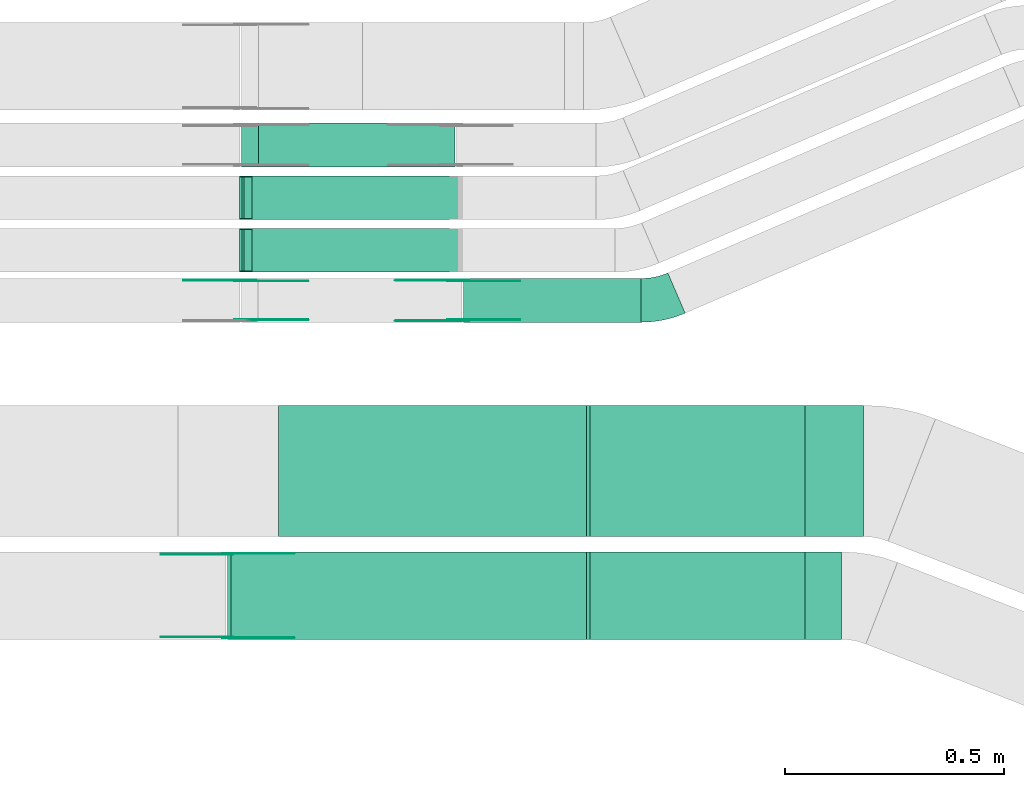
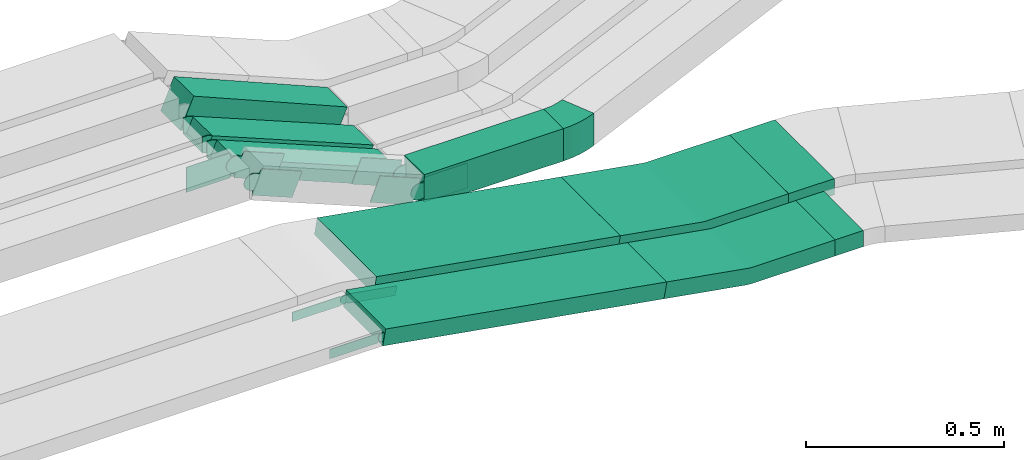
# One storey, part 16 of 31: 16 flow fittings, 8 flow segments.
"""IFC2X3 building model written with IfcOpenShell, lengths in millimetres."""

from ifc_helpers import new_model, entity, si_unit, converted_unit, derived_unit, direction, frame, frame_2d, origin, origin_2d_with_axis, place, context, subcontext, project, spatial, polyline, circle_curve, parameter, trimmed, segment, composite_curve, rectangle, outline, extrude, faceted_brep, source, transform, mapped, material, type_object, type_shapes, element, save


model = new_model("IFC2X3")

# Units and contexts
model_context = context("Model", 3, precision=0.01, world=origin(), true_north=direction((6.12303176911189e-17, 1.0)))
body_context = subcontext(model_context, "Body", "Model", "MODEL_VIEW")
ifc_project = project(units=[si_unit("LENGTHUNIT", "METRE", prefix="MILLI"), si_unit("AREAUNIT", "SQUARE_METRE"), si_unit("VOLUMEUNIT", "CUBIC_METRE"), converted_unit("PLANEANGLEUNIT", "DEGREE", entity("IfcRatioMeasure", 0.0174532925199433), si_unit("PLANEANGLEUNIT", "RADIAN"), dimensions=[0, 0, 0, 0, 0, 0, 0]), si_unit("MASSUNIT", "GRAM", prefix="KILO"), derived_unit("MASSDENSITYUNIT", [(si_unit("MASSUNIT", "GRAM", prefix="KILO"), 1), (si_unit("LENGTHUNIT", "METRE"), -3)]), derived_unit("MOMENTOFINERTIAUNIT", [(si_unit("LENGTHUNIT", "METRE"), 4)]), si_unit("TIMEUNIT", "SECOND"), si_unit("FREQUENCYUNIT", "HERTZ"), si_unit("THERMODYNAMICTEMPERATUREUNIT", "DEGREE_CELSIUS"), derived_unit("THERMALTRANSMITTANCEUNIT", [(si_unit("MASSUNIT", "GRAM", prefix="KILO"), 1), (si_unit("THERMODYNAMICTEMPERATUREUNIT", "KELVIN"), -1), (si_unit("TIMEUNIT", "SECOND"), -3)]), derived_unit("VOLUMETRICFLOWRATEUNIT", [(si_unit("LENGTHUNIT", "METRE"), 3), (si_unit("TIMEUNIT", "SECOND"), -1)]), derived_unit("MASSFLOWRATEUNIT", [(si_unit("MASSUNIT", "GRAM", prefix="KILO"), 1), (si_unit("TIMEUNIT", "SECOND"), -1)]), derived_unit("ROTATIONALFREQUENCYUNIT", [(si_unit("TIMEUNIT", "SECOND"), -1)]), si_unit("ELECTRICCURRENTUNIT", "AMPERE"), si_unit("ELECTRICVOLTAGEUNIT", "VOLT"), si_unit("POWERUNIT", "WATT"), si_unit("FORCEUNIT", "NEWTON", prefix="KILO"), si_unit("ILLUMINANCEUNIT", "LUX"), si_unit("LUMINOUSFLUXUNIT", "LUMEN"), si_unit("LUMINOUSINTENSITYUNIT", "CANDELA"), derived_unit("USERDEFINED", [(si_unit("MASSUNIT", "GRAM", prefix="KILO"), -1), (si_unit("LENGTHUNIT", "METRE"), -2), (si_unit("TIMEUNIT", "SECOND"), 3), (si_unit("LUMINOUSFLUXUNIT", "LUMEN"), 1)]), derived_unit("LINEARVELOCITYUNIT", [(si_unit("LENGTHUNIT", "METRE"), 1), (si_unit("TIMEUNIT", "SECOND"), -1)]), si_unit("PRESSUREUNIT", "PASCAL"), derived_unit("USERDEFINED", [(si_unit("LENGTHUNIT", "METRE"), -2), (si_unit("MASSUNIT", "GRAM", prefix="KILO"), 1), (si_unit("TIMEUNIT", "SECOND"), -2)]), derived_unit("LINEARFORCEUNIT", [(si_unit("MASSUNIT", "GRAM", prefix="KILO"), 1), (si_unit("LENGTHUNIT", "METRE"), 1), (si_unit("TIMEUNIT", "SECOND"), -2), (si_unit("LENGTHUNIT", "METRE"), -1)]), derived_unit("PLANARFORCEUNIT", [(si_unit("MASSUNIT", "GRAM", prefix="KILO"), 1), (si_unit("LENGTHUNIT", "METRE"), 1), (si_unit("TIMEUNIT", "SECOND"), -2), (si_unit("LENGTHUNIT", "METRE"), -2)])], contexts=[model_context])

# Site, building, storey
site_placement = place(None, frame((0.0, -0.00077364408347762, 0.0)))
site = spatial("IfcSite", under=ifc_project, at=site_placement, CompositionType="ELEMENT")
building_placement = place(site_placement, origin())
building = spatial("IfcBuilding", under=site, at=building_placement, CompositionType="ELEMENT")
storey_placement = place(building_placement, frame((0.0, 0.0, 15900.0)))
storey = spatial("IfcBuildingStorey", under=building, at=storey_placement, CompositionType="ELEMENT", Elevation=15900.0)

# Flow segments
cable_carrier_segment_type = type_object("IfcCableCarrierSegmentType", PredefinedType="CABLETRAYSEGMENT")
flow_segment_1_placement = place(storey_placement, frame((45693.9474929128, 15124.9939089947, 2634.94956318969)))
element("IfcFlowSegment", 1, at=flow_segment_1_placement, inside=storey, type_object=cable_carrier_segment_type, context=body_context, shape_type="SweptSolid", body=[
    extrude(rectangle(XDim=406.031422459047, YDim=99.9999999999989, at=frame_2d((0.0, -1.08357767203415e-12), x_axis=(1.0, 0.0))), frame((203.015711229523, 50.0, 0.0)), (0.0, 0.0, 1.0), 99.9999999999989),
])
flow_segment_2_placement = place(storey_placement, frame((45191.3085759631, 15239.4580000517, 2642.86123897901)))
element("IfcFlowSegment", 2, at=flow_segment_2_placement, inside=storey, type_object=cable_carrier_segment_type, context=body_context, shape_type="SweptSolid", body=[
    extrude(rectangle(XDim=50.0000000000019, YDim=99.9999999999989, at=frame_2d((-1.00186525742174e-12, 2.16715534406831e-12), x_axis=(1.0, 0.0))), frame((9.49229224874441, 50.0, 216.395545412713), z_axis=(0.925113085294563, 0.0, -0.379691689949589), x_axis=(0.379691689949589, 0.0, 0.925113085294563)), (0.0, 0.0, 1.0), 509.012241763836),
])
flow_segment_3_placement = place(storey_placement, frame((45191.308575963, 15359.4580000518, 2642.86123897902)))
element("IfcFlowSegment", 3, at=flow_segment_3_placement, inside=storey, type_object=cable_carrier_segment_type, context=body_context, shape_type="SweptSolid", body=[
    extrude(rectangle(XDim=50.0000000000092, YDim=99.9999999999989, at=origin_2d_with_axis()), frame((9.49229224874441, 50.0, 216.395545412369), z_axis=(0.925113085294515, 0.0, -0.379691689949707), x_axis=(0.379691689949707, 0.0, 0.925113085294515)), (0.0, 0.0, 1.0), 509.012241762945),
])
flow_segment_4_placement = place(storey_placement, frame((45186.4911009639, 15479.9939089947, 2643.66817627978)))
element("IfcFlowSegment", 4, at=flow_segment_4_placement, inside=storey, type_object=cable_carrier_segment_type, context=body_context, shape_type="SweptSolid", body=[
    extrude(rectangle(XDim=99.9999999999968, YDim=99.9999999999989, at=frame_2d((0.0, -2.16715534406831e-12), x_axis=(1.0, 0.0))), frame((19.5475726940318, 50.0, 236.643082452827), z_axis=(0.92041129975061, 0.0, -0.390951453880648), x_axis=(0.390951453880648, 0.0, 0.92041129975061)), (0.0, 0.0, 1.0), 487.586158263763),
])
flow_segment_5_placement = place(storey_placement, frame((46475.2400350506, 14635.0255085139, 2650.0)))
element("IfcFlowSegment", 5, at=flow_segment_5_placement, inside=storey, type_object=cable_carrier_segment_type, context=body_context, shape_type="SweptSolid", body=[
    extrude(rectangle(XDim=133.135877151261, YDim=300.000000000001, at=origin_2d_with_axis()), frame((66.5679385756305, 150.0, 0.0), z_axis=(0.0, 0.0, 1.0), x_axis=(-1.0, 0.0, 0.0)), (0.0, 0.0, 1.0), 50.0000000000016),
])
flow_segment_6_placement = place(storey_placement, frame((46475.2400350506, 14400.0255085139, 2650.0)))
element("IfcFlowSegment", 6, at=flow_segment_6_placement, inside=storey, type_object=cable_carrier_segment_type, context=body_context, shape_type="SweptSolid", body=[
    extrude(rectangle(XDim=82.4973887325516, YDim=200.000000000002, at=frame_2d((-4.33075797445781e-12, 0.0), x_axis=(1.0, 0.0))), frame((41.2486943662715, 100.0, 0.0), z_axis=(0.0, 0.0, 1.0), x_axis=(-1.0, 0.0, 0.0)), (0.0, 0.0, 1.0), 50.0000000000038),
])
flow_segment_7_placement = place(storey_placement, frame((45154.3195818992, 14400.0255085139, 2692.89003524465)))
element("IfcFlowSegment", 7, at=flow_segment_7_placement, inside=storey, type_object=cable_carrier_segment_type, context=body_context, shape_type="SweptSolid", body=[
    extrude(rectangle(XDim=49.9999999999991, YDim=199.999999999998, at=origin_2d_with_axis()), frame((4.25767461585183, 100.0, 166.51599836149), z_axis=(0.985391054853274, 0.0, -0.170306984634076), x_axis=(0.170306984634076, 0.0, 0.985391054853274)), (0.0, 0.0, 1.0), 833.091034374861),
])
flow_segment_8_placement = place(storey_placement, frame((45262.9235421238, 14635.0255085139, 2692.89003524465)))
element("IfcFlowSegment", 8, at=flow_segment_8_placement, inside=storey, type_object=cable_carrier_segment_type, context=body_context, shape_type="SweptSolid", body=[
    extrude(rectangle(XDim=49.9999999999991, YDim=300.000000000001, at=origin_2d_with_axis()), frame((4.25767461585183, 150.0, 147.745772171508), z_axis=(0.985391054853274, 0.0, -0.170306984634076), x_axis=(0.170306984634076, 0.0, 0.985391054853274)), (0.0, 0.0, 1.0), 722.876962824568),
])

# Flow fittings
ifc_material_1 = material(Name="G")
cable_carrier_fitting_type_1 = type_object("IfcCableCarrierFittingType", PredefinedType="NOTDEFINED", material=ifc_material_1)
shared_shape_1 = source(origin(), body_context, "Body", "SweptSolid", [
    extrude(outline(composite_curve([segment(trimmed(circle_curve(frame_2d((-44.5901162790698, 0.0), x_axis=(1.0, 0.0)), 12.5), [parameter(90.0000000000007)], [parameter(270.0)], True, "PARAMETER"), True, "CONTINUOUS"), segment(polyline([(-44.5901162790697, -12.5), (-33.0901162790698, -12.5)]), True, "CONTINUOUS"), segment(polyline([(-33.0901162790698, -12.5), (-31.2296511627907, -14.5)]), True, "CONTINUOUS"), segment(polyline([(-31.2296511627907, -14.5), (108.90988372093, -14.5)]), True, "CONTINUOUS"), segment(polyline([(108.90988372093, -14.5), (108.90988372093, 14.5)]), True, "CONTINUOUS"), segment(polyline([(108.90988372093, 14.5), (-31.2296511627907, 14.5)]), True, "CONTINUOUS"), segment(polyline([(-31.2296511627907, 14.5), (-33.0901162790698, 12.5)]), True, "CONTINUOUS"), segment(polyline([(-33.0901162790698, 12.5), (-44.5901162790699, 12.5)]), True, "CONTINUOUS")], self_intersect=False)), frame((44.5901162790698, 0.0, 0.0), z_axis=(0.0, 0.0, -1.0), x_axis=(1.0, 0.0, 0.0)), (0.0, 0.0, -1.0), 2.0),
])
type_shapes(cable_carrier_fitting_type_1, [shared_shape_1])
flow_fitting_1_placement = place(storey_placement, frame((45155.14058495, 14595.4855085241, 2860.0), z_axis=(0.0, 1.0, 0.0), x_axis=(0.985391054853256, 0.0, -0.170306984634182)))
element("IfcFlowFitting", 9, at=flow_fitting_1_placement, inside=storey, type_object=cable_carrier_fitting_type_1, material=ifc_material_1, context=body_context, shape_type="MappedRepresentation", body=[
    mapped(shared_shape_1, transform((0.0, 0.0, 0.0), scale=1.0)),
])
cable_carrier_fitting_type_2 = type_object("IfcCableCarrierFittingType", PredefinedType="NOTDEFINED", material=ifc_material_1)
shared_shape_2 = source(origin(), body_context, "Body", "SweptSolid", [
    extrude(outline(composite_curve([segment(trimmed(circle_curve(frame_2d((-44.5901162790697, 0.0), x_axis=(1.0, 0.0)), 12.5), [parameter(90.0000000000007)], [parameter(270.0)], True, "PARAMETER"), True, "CONTINUOUS"), segment(polyline([(-44.5901162790697, -12.5), (-33.0901162790697, -12.5)]), True, "CONTINUOUS"), segment(polyline([(-33.0901162790697, -12.5), (-31.2296511627907, -14.5)]), True, "CONTINUOUS"), segment(polyline([(-31.2296511627907, -14.5), (108.90988372093, -14.5)]), True, "CONTINUOUS"), segment(polyline([(108.90988372093, -14.5), (108.90988372093, 14.5)]), True, "CONTINUOUS"), segment(polyline([(108.90988372093, 14.5), (-31.2296511627907, 14.5)]), True, "CONTINUOUS"), segment(polyline([(-31.2296511627907, 14.5), (-33.0901162790698, 12.5)]), True, "CONTINUOUS"), segment(polyline([(-33.0901162790698, 12.5), (-44.5901162790699, 12.5)]), True, "CONTINUOUS")], self_intersect=False)), frame((44.5901162790697, 0.0, 0.0)), (0.0, 0.0, 1.0), 2.0),
])
type_shapes(cable_carrier_fitting_type_2, [shared_shape_2])
flow_fitting_2_placement = place(storey_placement, frame((45155.14058495, 14404.5655085037, 2860.0), z_axis=(0.0, -1.0, 0.0), x_axis=(0.985391054853256, 0.0, -0.170306984634182)))
element("IfcFlowFitting", 10, at=flow_fitting_2_placement, inside=storey, type_object=cable_carrier_fitting_type_2, material=ifc_material_1, context=body_context, shape_type="MappedRepresentation", body=[
    mapped(shared_shape_2, transform((0.0, 0.0, 0.0), scale=1.0)),
])
cable_carrier_fitting_type_3 = type_object("IfcCableCarrierFittingType", PredefinedType="NOTDEFINED", material=ifc_material_1)
shared_shape_3 = source(origin(), body_context, "Body", "SweptSolid", [
    extrude(outline(composite_curve([segment(trimmed(circle_curve(frame_2d((-44.5901162790698, 0.0), x_axis=(1.0, 0.0)), 12.5), [parameter(90.0000000000007)], [parameter(270.0)], True, "PARAMETER"), True, "CONTINUOUS"), segment(polyline([(-44.5901162790697, -12.5), (-33.0901162790698, -12.5)]), True, "CONTINUOUS"), segment(polyline([(-33.0901162790698, -12.5), (-31.2296511627907, -14.5)]), True, "CONTINUOUS"), segment(polyline([(-31.2296511627907, -14.5), (108.90988372093, -14.5)]), True, "CONTINUOUS"), segment(polyline([(108.90988372093, -14.5), (108.90988372093, 14.5)]), True, "CONTINUOUS"), segment(polyline([(108.90988372093, 14.5), (-31.2296511627907, 14.5)]), True, "CONTINUOUS"), segment(polyline([(-31.2296511627907, 14.5), (-33.0901162790698, 12.5)]), True, "CONTINUOUS"), segment(polyline([(-33.0901162790698, 12.5), (-44.5901162790699, 12.5)]), True, "CONTINUOUS")], self_intersect=False)), frame((44.5901162790698, 0.0, 0.0), z_axis=(0.0, 0.0, -1.0), x_axis=(1.0, 0.0, 0.0)), (0.0, 0.0, -1.0), 2.0),
])
type_shapes(cable_carrier_fitting_type_3, [shared_shape_3])
flow_fitting_3_placement = place(storey_placement, frame((45155.14058495, 14406.5655085037, 2860.0), z_axis=(0.0, -1.0, 0.0), x_axis=(-1.0, 0.0, 0.0)))
element("IfcFlowFitting", 11, at=flow_fitting_3_placement, inside=storey, type_object=cable_carrier_fitting_type_3, material=ifc_material_1, context=body_context, shape_type="MappedRepresentation", body=[
    mapped(shared_shape_3, transform((0.0, 0.0, 0.0), scale=1.0)),
])
cable_carrier_fitting_type_4 = type_object("IfcCableCarrierFittingType", PredefinedType="NOTDEFINED", material=ifc_material_1)
shared_shape_4 = source(origin(), body_context, "Body", "SweptSolid", [
    extrude(outline(composite_curve([segment(trimmed(circle_curve(frame_2d((-44.5901162790697, 0.0), x_axis=(1.0, 0.0)), 12.5), [parameter(90.0000000000007)], [parameter(270.0)], True, "PARAMETER"), True, "CONTINUOUS"), segment(polyline([(-44.5901162790697, -12.5), (-33.0901162790697, -12.5)]), True, "CONTINUOUS"), segment(polyline([(-33.0901162790697, -12.5), (-31.2296511627907, -14.5)]), True, "CONTINUOUS"), segment(polyline([(-31.2296511627907, -14.5), (108.90988372093, -14.5)]), True, "CONTINUOUS"), segment(polyline([(108.90988372093, -14.5), (108.90988372093, 14.5)]), True, "CONTINUOUS"), segment(polyline([(108.90988372093, 14.5), (-31.2296511627907, 14.5)]), True, "CONTINUOUS"), segment(polyline([(-31.2296511627907, 14.5), (-33.0901162790698, 12.5)]), True, "CONTINUOUS"), segment(polyline([(-33.0901162790698, 12.5), (-44.5901162790699, 12.5)]), True, "CONTINUOUS")], self_intersect=False)), frame((44.5901162790697, 0.0, 0.0)), (0.0, 0.0, 1.0), 2.0),
])
type_shapes(cable_carrier_fitting_type_4, [shared_shape_4])
flow_fitting_4_placement = place(storey_placement, frame((45155.14058495, 14593.485508524, 2860.0), z_axis=(0.0, 1.0, 0.0), x_axis=(-1.0, 0.0, 0.0)))
element("IfcFlowFitting", 12, at=flow_fitting_4_placement, inside=storey, type_object=cable_carrier_fitting_type_4, material=ifc_material_1, context=body_context, shape_type="MappedRepresentation", body=[
    mapped(shared_shape_4, transform((0.0, 0.0, 0.0), scale=1.0)),
])
cable_carrier_fitting_type_5 = type_object("IfcCableCarrierFittingType", PredefinedType="NOTDEFINED", material=ifc_material_1)
shared_shape_5 = source(origin(), body_context, "Body", "SweptSolid", [
    extrude(outline(composite_curve([segment(trimmed(circle_curve(frame_2d((-41.4651162790697, 0.0), x_axis=(1.0, 0.0)), 25.0), [parameter(90.0000000000007)], [parameter(270.0)], True, "PARAMETER"), True, "CONTINUOUS"), segment(polyline([(-41.4651162790697, -25.0), (-29.9651162790697, -25.0)]), True, "CONTINUOUS"), segment(polyline([(-29.9651162790697, -25.0), (-28.1046511627907, -38.5)]), True, "CONTINUOUS"), segment(polyline([(-28.1046511627907, -38.5), (99.5348837209303, -38.5)]), True, "CONTINUOUS"), segment(polyline([(99.5348837209303, -38.5), (99.5348837209303, 38.5)]), True, "CONTINUOUS"), segment(polyline([(99.5348837209303, 38.5), (-28.1046511627907, 38.5)]), True, "CONTINUOUS"), segment(polyline([(-28.1046511627907, 38.5), (-29.9651162790697, 25.0)]), True, "CONTINUOUS"), segment(polyline([(-29.9651162790697, 25.0), (-41.46511627907, 25.0)]), True, "CONTINUOUS")], self_intersect=False)), frame((41.4651162790697, 0.0, 0.0), z_axis=(0.0, 0.0, -1.0), x_axis=(1.0, 0.0, 0.0)), (0.0, 0.0, -1.0), 2.0),
])
type_shapes(cable_carrier_fitting_type_5, [shared_shape_5])
flow_fitting_5_placement = place(storey_placement, frame((45682.2970270189, 15220.4539090049, 2684.94956318967), z_axis=(0.0, 1.0, 0.0), x_axis=(-0.925113085296403, 0.0, 0.379691689945105)))
element("IfcFlowFitting", 13, at=flow_fitting_5_placement, inside=storey, type_object=cable_carrier_fitting_type_5, material=ifc_material_1, context=body_context, shape_type="MappedRepresentation", body=[
    mapped(shared_shape_5, transform((0.0, 0.0, 0.0), scale=1.0)),
])
cable_carrier_fitting_type_6 = type_object("IfcCableCarrierFittingType", PredefinedType="NOTDEFINED", material=ifc_material_1)
shared_shape_6 = source(origin(), body_context, "Body", "SweptSolid", [
    extrude(outline(composite_curve([segment(trimmed(circle_curve(frame_2d((-41.4651162790697, 0.0), x_axis=(1.0, 0.0)), 25.0), [parameter(90.0000000000007)], [parameter(270.0)], True, "PARAMETER"), True, "CONTINUOUS"), segment(polyline([(-41.4651162790697, -25.0), (-29.9651162790697, -25.0)]), True, "CONTINUOUS"), segment(polyline([(-29.9651162790697, -25.0), (-28.1046511627907, -38.5)]), True, "CONTINUOUS"), segment(polyline([(-28.1046511627907, -38.5), (99.5348837209303, -38.5)]), True, "CONTINUOUS"), segment(polyline([(99.5348837209303, -38.5), (99.5348837209303, 38.5)]), True, "CONTINUOUS"), segment(polyline([(99.5348837209303, 38.5), (-28.1046511627907, 38.5)]), True, "CONTINUOUS"), segment(polyline([(-28.1046511627907, 38.5), (-29.9651162790697, 25.0)]), True, "CONTINUOUS"), segment(polyline([(-29.9651162790697, 25.0), (-41.46511627907, 25.0)]), True, "CONTINUOUS")], self_intersect=False)), frame((41.4651162790697, 0.0, 0.0)), (0.0, 0.0, 1.0), 2.0),
])
type_shapes(cable_carrier_fitting_type_6, [shared_shape_6])
for number, where, z_axis, x_axis in (
    (14, (45194.98232223, 15220.4539090049, 2884.95683445177), (0.0, 1.0, 0.0), (-1.0, 0.0, 0.0)),
    (15, (45682.2970270189, 15129.5339089845, 2684.94956318967), (0.0, -1.0, 0.0), (-0.925113085296403, 0.0, 0.379691689945105)),
):
    element("IfcFlowFitting", number, at=place(storey_placement, frame(where, z_axis=z_axis, x_axis=x_axis)), inside=storey, type_object=cable_carrier_fitting_type_6, material=ifc_material_1, context=body_context, shape_type="MappedRepresentation", body=[
        mapped(shared_shape_6, transform((0.0, 0.0, 0.0), scale=1.0)),
    ])
cable_carrier_fitting_type_7 = type_object("IfcCableCarrierFittingType", PredefinedType="NOTDEFINED", material=ifc_material_1)
shared_shape_7 = source(origin(), body_context, "Body", "SweptSolid", [
    extrude(outline(composite_curve([segment(trimmed(circle_curve(frame_2d((-41.4651162790697, 0.0), x_axis=(1.0, 0.0)), 25.0), [parameter(90.0000000000007)], [parameter(270.0)], True, "PARAMETER"), True, "CONTINUOUS"), segment(polyline([(-41.4651162790697, -25.0), (-29.9651162790697, -25.0)]), True, "CONTINUOUS"), segment(polyline([(-29.9651162790697, -25.0), (-28.1046511627907, -38.5)]), True, "CONTINUOUS"), segment(polyline([(-28.1046511627907, -38.5), (99.5348837209303, -38.5)]), True, "CONTINUOUS"), segment(polyline([(99.5348837209303, -38.5), (99.5348837209303, 38.5)]), True, "CONTINUOUS"), segment(polyline([(99.5348837209303, 38.5), (-28.1046511627907, 38.5)]), True, "CONTINUOUS"), segment(polyline([(-28.1046511627907, 38.5), (-29.9651162790697, 25.0)]), True, "CONTINUOUS"), segment(polyline([(-29.9651162790697, 25.0), (-41.46511627907, 25.0)]), True, "CONTINUOUS")], self_intersect=False)), frame((41.4651162790697, 0.0, 0.0), z_axis=(0.0, 0.0, -1.0), x_axis=(1.0, 0.0, 0.0)), (0.0, 0.0, -1.0), 2.0),
])
type_shapes(cable_carrier_fitting_type_7, [shared_shape_7])
for number, where, z_axis, x_axis in (
    (16, (45194.98232223, 15218.4539090049, 2884.95683445177), (0.0, 1.0, 0.0), (0.925113085294536, 0.0, -0.379691689949654)),
    (17, (45682.2970270189, 15131.5339089845, 2684.94956318968), (0.0, -1.0, 0.0), (1.0, 0.0, 0.0)),
):
    element("IfcFlowFitting", number, at=place(storey_placement, frame(where, z_axis=z_axis, x_axis=x_axis)), inside=storey, type_object=cable_carrier_fitting_type_7, material=ifc_material_1, context=body_context, shape_type="MappedRepresentation", body=[
        mapped(shared_shape_7, transform((0.0, 0.0, 0.0), scale=1.0)),
    ])
cable_carrier_fitting_type_8 = type_object("IfcCableCarrierFittingType", PredefinedType="NOTDEFINED", material=ifc_material_1)
shared_shape_8 = source(origin(), body_context, "Body", "SweptSolid", [
    extrude(outline(composite_curve([segment(trimmed(circle_curve(frame_2d((-41.4651162790697, 0.0), x_axis=(1.0, 0.0)), 25.0), [parameter(90.0000000000007)], [parameter(270.0)], True, "PARAMETER"), True, "CONTINUOUS"), segment(polyline([(-41.4651162790697, -25.0), (-29.9651162790697, -25.0)]), True, "CONTINUOUS"), segment(polyline([(-29.9651162790697, -25.0), (-28.1046511627907, -38.5)]), True, "CONTINUOUS"), segment(polyline([(-28.1046511627907, -38.5), (99.5348837209303, -38.5)]), True, "CONTINUOUS"), segment(polyline([(99.5348837209303, -38.5), (99.5348837209303, 38.5)]), True, "CONTINUOUS"), segment(polyline([(99.5348837209303, 38.5), (-28.1046511627907, 38.5)]), True, "CONTINUOUS"), segment(polyline([(-28.1046511627907, 38.5), (-29.9651162790697, 25.0)]), True, "CONTINUOUS"), segment(polyline([(-29.9651162790697, 25.0), (-41.46511627907, 25.0)]), True, "CONTINUOUS")], self_intersect=False)), frame((41.4651162790697, 0.0, 0.0)), (0.0, 0.0, 1.0), 2.0),
])
type_shapes(cable_carrier_fitting_type_8, [shared_shape_8])
for number, where, z_axis, x_axis in (
    (18, (45194.98232223, 15131.5339089845, 2884.95683445177), (0.0, -1.0, 0.0), (0.925113085294536, 0.0, -0.379691689949654)),
    (19, (45682.2970270189, 15218.4539090049, 2684.94956318968), (0.0, 1.0, 0.0), (1.0, 0.0, 0.0)),
):
    element("IfcFlowFitting", number, at=place(storey_placement, frame(where, z_axis=z_axis, x_axis=x_axis)), inside=storey, type_object=cable_carrier_fitting_type_8, material=ifc_material_1, context=body_context, shape_type="MappedRepresentation", body=[
        mapped(shared_shape_8, transform((0.0, 0.0, 0.0), scale=1.0)),
    ])
ifc_material_2 = material()
cable_carrier_fitting_type_9 = type_object("IfcCableCarrierFittingType", PredefinedType="NOTDEFINED", material=ifc_material_2)
shared_shape_9 = source(origin(), body_context, "Body", "Brep", [
    faceted_brep([(-9.86154249456779, 25.0, 50.0), (-9.86154249456779, 25.0, -50.0), (-9.86154249456795, -25.0, -50.0), (-9.86154249456795, -25.0, -47.4600000101565), (-9.8615424945678, 22.46000001016, -47.4600000101565), (-9.8615424945678, 22.46000001016, 47.4600000101635), (-9.86154249456795, -25.0, 47.4600000101635), (-9.86154249456795, -25.0, 50.0), (-0.369250245826843, 26.8721728676359, 50.0), (18.6153342516549, -19.3834813970913, 50.0), (18.6153342516549, -19.3834813970913, 47.4600000101635), (0.595166642787549, 24.522385640387, 47.4600000101635), (0.595166642787553, 24.522385640387, -47.4600000101565), (18.6153342516549, -19.3834813970913, -47.4600000101565), (18.6153342516549, -19.3834813970913, -50.0), (-0.369250245826849, 26.8721728676359, -50.0), (-4.93077124728357, 25.0, 50.0), (-4.93077124728367, 25.0, -50.0), (4.93077124728457, -25.0, -50.0), (4.93077124728457, -25.0, -47.4600000101565), (-4.42980489056346, 22.46000001016, -47.4600000101565), (-4.42980489056346, 22.46000001016, 47.4600000101635), (4.93077124728457, -25.0, 47.4600000101635), (4.93077124728457, -25.0, 50.0)], [[[0, 1, 2, 3, 4, 5, 6, 7]], [[8, 9, 10, 11, 12, 13, 14, 15]], [[1, 0, 16, 17]], [[2, 1, 17, 15, 14, 18]], [[3, 2, 18, 19]], [[4, 3, 19, 13, 12, 20]], [[5, 4, 20, 21]], [[6, 5, 21, 11, 10, 22]], [[7, 6, 22, 23]], [[0, 7, 23, 9, 8, 16]], [[17, 16, 8, 15]], [[19, 18, 14, 13]], [[21, 20, 12, 11]], [[23, 22, 10, 9]]]),
])
type_shapes(cable_carrier_fitting_type_9, [shared_shape_9])
for number, where, z_axis, x_axis in (
    (20, (45191.677826209, 15289.4580000518, 2863.00113012698), (0.0, 1.0, 0.0), (1.0, 0.0, 0.0)),
    (21, (45191.6778262088, 15409.4580000518, 2863.00113012666), (0.0, 1.0, 0.0), (1.0, 0.0, 0.0)),
):
    element("IfcFlowFitting", number, at=place(storey_placement, frame(where, z_axis=z_axis, x_axis=x_axis)), inside=storey, type_object=cable_carrier_fitting_type_9, material=ifc_material_2, context=body_context, shape_type="MappedRepresentation", body=[
        mapped(shared_shape_9, transform((0.0, 0.0, 0.0), scale=1.0)),
    ])
cable_carrier_fitting_type_10 = type_object("IfcCableCarrierFittingType", Name="470_DKC_S5_CS 90 internal vertical angle:-", PredefinedType="NOTDEFINED", material=ifc_material_2)
shared_shape_10 = source(origin(), body_context, "Body", "SweptSolid", [
    extrude(outline(composite_curve([segment(polyline([(-248.739247554508, -36.1425159841328), (-11.0534040619563, -36.1425159841328)]), True, "CONTINUOUS"), segment(trimmed(circle_curve(frame_2d((-11.0534040619567, 128.857484015866), x_axis=(0.0, -1.0)), 164.999999999999), [parameter(0.0)], [parameter(9.80566826552612)], True, "PARAMETER"), True, "CONTINUOUS"), segment(polyline([(17.0472484026801, -33.7320400349206), (251.260752445492, 6.74751926052297)]), True, "CONTINUOUS"), segment(polyline([(251.260752445492, 6.74751926052297), (242.745403213784, 56.0170720031862)]), True, "CONTINUOUS"), segment(polyline([(242.745403213784, 56.0170720031862), (8.53189917097189, 15.5375127077426)]), True, "CONTINUOUS"), segment(trimmed(circle_curve(frame_2d((-11.0534040619567, 128.857484015866), x_axis=(0.0, -1.0)), 114.999999999999), [parameter(0.0)], [parameter(9.80566826552612)], True, "PARAMETER"), False, "CONTINUOUS"), segment(polyline([(-11.0534040619563, 13.8574840158674), (-248.739247554508, 13.8574840158674)]), True, "CONTINUOUS"), segment(polyline([(-248.739247554508, 13.8574840158674), (-248.739247554508, -36.1425159841328)]), True, "CONTINUOUS")], self_intersect=False)), frame((-0.955805806538213, 11.1425159841255, -100.0)), (0.0, 0.0, 1.0), 200.0),
])
type_shapes(cable_carrier_fitting_type_10, [shared_shape_10])
flow_fitting_6_placement = place(storey_placement, frame((46225.5449816896, 14500.0255085139, 2675.0), z_axis=(0.0, 1.0, 0.0), x_axis=(-1.0, 0.0, 0.0)))
element("IfcFlowFitting", 22, at=flow_fitting_6_placement, inside=storey, type_object=cable_carrier_fitting_type_10, material=ifc_material_2, Name="470_DKC_S5_CS 90 internal vertical angle:-", ObjectType="470_DKC_S5_CS 90 internal vertical angle:-", context=body_context, shape_type="MappedRepresentation", body=[
    mapped(shared_shape_10, transform((0.0, 0.0, 0.0), scale=1.0)),
])
cable_carrier_fitting_type_11 = type_object("IfcCableCarrierFittingType", Name="470_DKC_S5_CS 90 internal vertical angle:-", PredefinedType="NOTDEFINED", material=ifc_material_2)
shared_shape_11 = source(origin(), body_context, "Body", "SweptSolid", [
    extrude(outline(composite_curve([segment(polyline([(-248.739247554508, -36.1425159841332), (-11.0534040619567, -36.1425159841332)]), True, "CONTINUOUS"), segment(trimmed(circle_curve(frame_2d((-11.053404061957, 128.857484015866), x_axis=(0.0, -1.0)), 164.999999999999), [parameter(0.0)], [parameter(9.80566826552648)], True, "PARAMETER"), True, "CONTINUOUS"), segment(polyline([(17.0472484026807, -33.7320400349208), (251.260752445492, 6.74751926052407)]), True, "CONTINUOUS"), segment(polyline([(251.260752445492, 6.74751926052406), (242.745403213784, 56.0170720031873)]), True, "CONTINUOUS"), segment(polyline([(242.745403213784, 56.0170720031873), (8.5318991709722, 15.5375127077423)]), True, "CONTINUOUS"), segment(trimmed(circle_curve(frame_2d((-11.053404061957, 128.857484015866), x_axis=(0.0, -1.0)), 114.999999999999), [parameter(0.0)], [parameter(9.80566826552648)], True, "PARAMETER"), False, "CONTINUOUS"), segment(polyline([(-11.0534040619567, 13.857484015867), (-248.739247554508, 13.857484015867)]), True, "CONTINUOUS"), segment(polyline([(-248.739247554508, 13.857484015867), (-248.739247554508, -36.1425159841332)]), True, "CONTINUOUS")], self_intersect=False)), frame((-0.955805806538289, 11.142515984126, -150.0)), (0.0, 0.0, 1.0), 300.0),
])
type_shapes(cable_carrier_fitting_type_11, [shared_shape_11])
flow_fitting_7_placement = place(storey_placement, frame((46225.5449816896, 14785.0255085139, 2675.0), z_axis=(0.0, 1.0, 0.0), x_axis=(-1.0, 0.0, 0.0)))
element("IfcFlowFitting", 23, at=flow_fitting_7_placement, inside=storey, type_object=cable_carrier_fitting_type_11, material=ifc_material_2, Name="470_DKC_S5_CS 90 internal vertical angle:-", ObjectType="470_DKC_S5_CS 90 internal vertical angle:-", context=body_context, shape_type="MappedRepresentation", body=[
    mapped(shared_shape_11, transform((0.0, 0.0, 0.0), scale=1.0)),
])
cable_carrier_fitting_type_12 = type_object("IfcCableCarrierFittingType", Name="470_DKC_S5_Variable Angle Elbow 0-45:-", PredefinedType="NOTDEFINED", material=ifc_material_2)
shared_shape_12 = source(origin(), body_context, "Body", "SweptSolid", [
    extrude(outline(composite_curve([segment(polyline([(-40.6063848287355, -58.2856004305556), (-39.6063848287342, -58.2856004305556)]), True, "CONTINUOUS"), segment(trimmed(circle_curve(frame_2d((-39.6063848287368, 191.714399569444), x_axis=(0.0, -1.0)), 250.0), [parameter(0.0)], [parameter(23.3451113937074)], True, "PARAMETER"), True, "CONTINUOUS"), segment(polyline([(59.4607430762446, -37.8192671739291), (60.378877743218, -37.4229986623092)]), True, "CONTINUOUS"), segment(polyline([(60.378877743218, -37.4229986623092), (20.7520265812255, 54.3904680350402)]), True, "CONTINUOUS"), segment(polyline([(20.7520265812256, 54.3904680350402), (19.833891914252, 53.9941995234202)]), True, "CONTINUOUS"), segment(trimmed(circle_curve(frame_2d((-39.6063848287368, 191.714399569444), x_axis=(0.0, -1.0)), 150.0), [parameter(0.0)], [parameter(23.3451113937074)], True, "PARAMETER"), False, "CONTINUOUS"), segment(polyline([(-39.6063848287351, 41.7143995694443), (-40.6063848287364, 41.7143995694443)]), True, "CONTINUOUS"), segment(polyline([(-40.6063848287364, 41.7143995694443), (-40.6063848287355, -58.2856004305556)]), True, "CONTINUOUS")], self_intersect=False)), frame((-1.7117268182506, 8.28560043054716, -50.0)), (0.0, 0.0, 1.0), 100.0),
])
type_shapes(cable_carrier_fitting_type_12, [shared_shape_12])
flow_fitting_8_placement = place(storey_placement, frame((46142.2970270189, 15174.9939089947, 2684.94956318969)))
element("IfcFlowFitting", 24, at=flow_fitting_8_placement, inside=storey, type_object=cable_carrier_fitting_type_12, material=ifc_material_2, Name="470_DKC_S5_Variable Angle Elbow 0-45:-", ObjectType="470_DKC_S5_Variable Angle Elbow 0-45:-", context=body_context, shape_type="MappedRepresentation", body=[
    mapped(shared_shape_12, transform((0.0, 0.0, 0.0), scale=1.0)),
])

save(model, "model.ifc")
